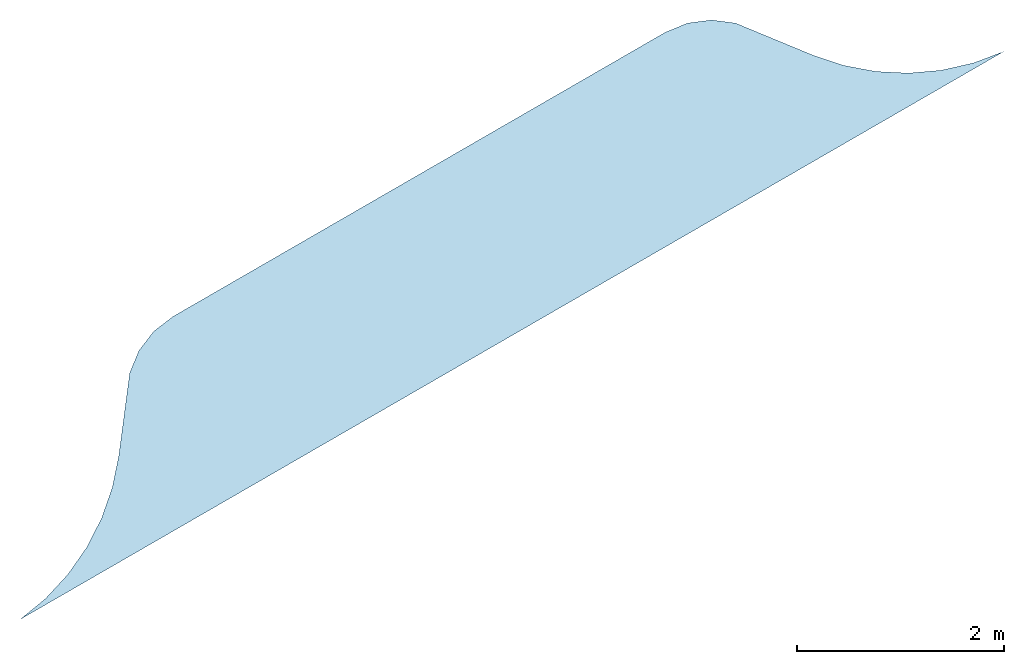
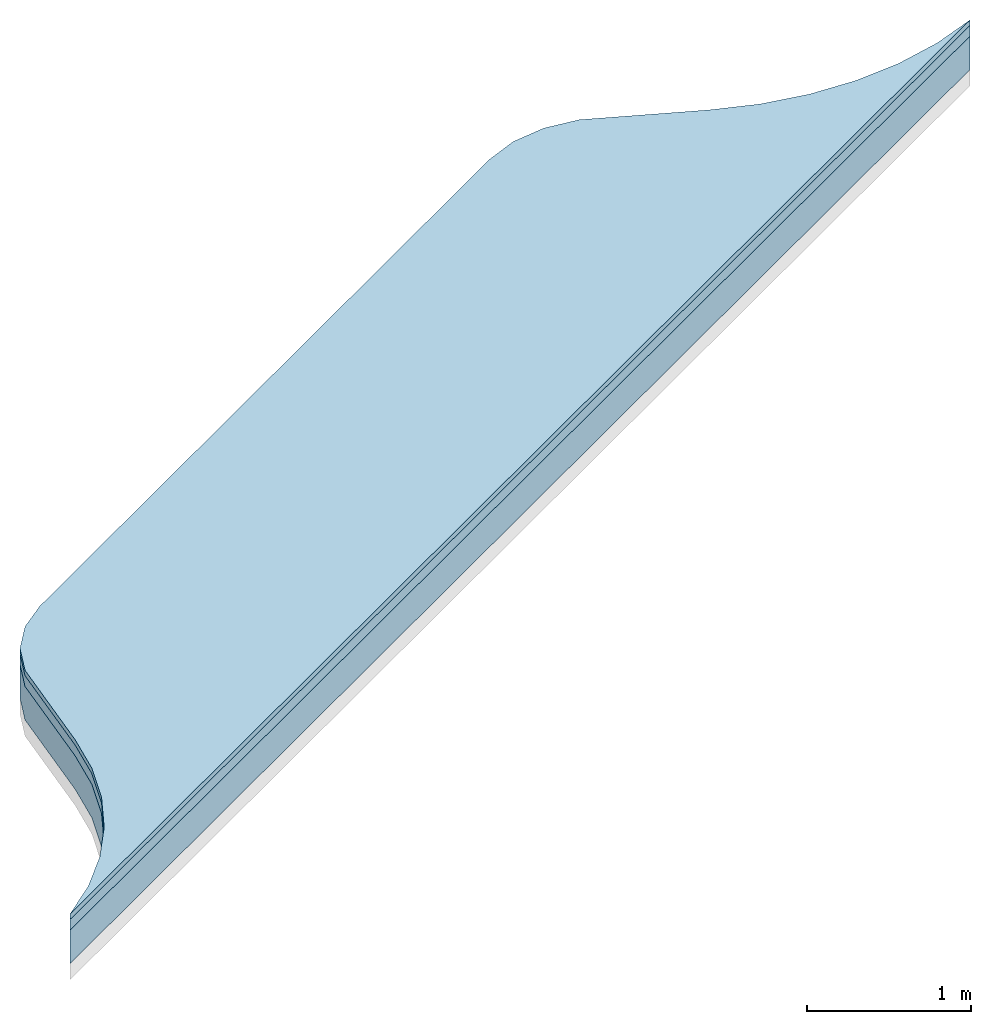
# One storey, part 1 of 2: 3 slabs.
"""IFC4 building model written with IfcOpenShell, lengths in millimetres."""

from ifc_helpers import new_model, si_unit, frame, origin_with_axes, place, context, subcontext, project, spatial, triangles, material, type_object, element, save


model = new_model("IFC4")

# Units and contexts
model_context = context("Model", 3, world=origin_with_axes())
body_context = subcontext(model_context, "Body", "Model", "MODEL_VIEW")
ifc_project = project(units=[si_unit("LENGTHUNIT", "METRE", prefix="MILLI"), si_unit("AREAUNIT", "SQUARE_METRE"), si_unit("VOLUMEUNIT", "CUBIC_METRE")], contexts=[model_context])

# Sites, buildings, storey
site_1_placement = place(None, origin_with_axes())
site_1 = spatial("IfcSite", under=ifc_project, at=site_1_placement, CompositionType="COMPLEX")
site_2_placement = place(site_1_placement, frame((1.7108101132749372e-11, 20000.000000000055, 0.0), z_axis=(0.0, 0.0, 1.0), x_axis=(-0.5000000000000002, 0.8660254037844387, 0.0)))
site_2 = spatial("IfcSite", under=site_1, at=site_2_placement, CompositionType="PARTIAL")
building_1_placement = place(site_2_placement, origin_with_axes())
building_1 = spatial("IfcBuilding", under=site_2, at=building_1_placement, Name="road parking - road", CompositionType="COMPLEX")
building_2_placement = place(building_1_placement, origin_with_axes())
building_2 = spatial("IfcBuilding", under=building_1, at=building_2_placement, Name="road parking - road segment", CompositionType="PARTIAL")
storey_placement = place(building_2_placement, origin_with_axes())
storey = spatial("IfcBuildingStorey", under=building_2, at=storey_placement, Name="road - parking", CompositionType="ELEMENT", Elevation=0.0)

# Slabs
ifc_material_1 = material(Name="bitumen_generic")
slab_type_1 = type_object("IfcSlabType", Name="asphalt course - road - parking", PredefinedType="USERDEFINED")
slab_1_placement = place(storey_placement, frame((7.796643330948427e-11, 8.060862910497234e-09, -9.023892744153272e-14), z_axis=(0.0, 0.0, 1.0), x_axis=(1.0, -1.1102230246251563e-16, 0.0)))
element("IfcSlab", 1, at=slab_1_placement, inside=storey, type_object=slab_type_1, material=ifc_material_1, Name="asphalt course - road - parking", ObjectType="core", context=body_context, shape_type="Tessellation", body=[
    triangles([(1800.0000000000064, -5500.000000008069, -39.99999999999848), (1851.8261465675155, 5185.984337374847, -39.999999999998295), (1799.9999999999834, 5499.999999991909, -39.99999999999848), (1851.8261465675148, -5185.984337390999, -39.999999999998295), (1946.0097838825307, -4881.975738336651, -39.999999999998025), (1946.009783882538, 4881.975738320503, -39.999999999998025), (2080.7895459400906, -4593.65958967934, -39.99999999999785), (2080.789545940087, 4593.659589663187, -39.99999999999785), (2253.6448623118463, 4326.427807423671, -39.99999999999766), (2253.6448623118577, -4326.427807439842, -39.99999999999766), (2461.3430963454293, 4085.278000423549, -39.999999999997485), (2461.343096345443, -4085.278000439709, -39.999999999997485), (2699.999999999992, 3874.720007996512, -39.99999999999739), (2699.999999999992, -3874.7200080126704, -39.99999999999739), (3336.3961030678715, -3386.396103083948, -39.99999999999739), (3336.396103067877, 3386.3961030677874, -39.99999999999739), (3479.422863405981, -3200.000000016058, -39.99999999999739), (3479.422863405978, 3199.999999999902, -39.99999999999739), (3569.3332436601595, 2982.937140592181, -39.99999999999739), (3569.333243660166, -2982.9371406083383, -39.99999999999739), (3600.0, 2749.999999999885, -39.99999999999739), (3600.000000000016, -2750.000000000095, -39.99999999999739), (1851.8261465675155, 5185.984337374847, -119.99999999999876), (1800.0000000000064, -5500.000000008069, -119.99999999999876), (1799.9999999999834, 5499.999999991909, -119.99999999999876), (1851.8261465675141, -5185.984337390999, -119.99999999999876), (1946.0097838825286, -4881.97573833665, -119.99999999999841), (1946.009783882538, 4881.975738320503, -119.99999999999841), (2080.7895459400884, -4593.65958967934, -119.99999999999804), (2080.789545940087, 4593.659589663187, -119.99999999999804), (2253.6448623118463, 4326.427807423671, -119.99999999999804), (2253.6448623118577, -4326.427807439842, -119.99999999999804), (2461.3430963454293, 4085.278000423549, -119.99999999999768), (2461.343096345443, -4085.278000439709, -119.99999999999768), (2699.999999999992, 3874.720007996512, -119.99999999999768), (2699.999999999992, -3874.7200080126704, -119.99999999999768), (3336.396103067877, 3386.3961030677874, -119.99999999999768), (3336.3961030678715, -3386.396103083948, -119.99999999999768), (3479.4228634059796, -3200.000000016059, -119.99999999999768), (3479.422863405978, 3199.999999999902, -119.99999999999768), (3569.3332436601595, 2982.937140592181, -119.99999999999768), (3569.333243660169, -2982.9371406083364, -119.99999999999768), (3600.0, 2749.999999999885, -119.99999999999768), (3600.000000000016, -2750.000000000095, -119.99999999999768), (1799.9999999999834, 5499.999999991909, -39.99999999999848), (1800.0000000000064, -5500.000000008069, -119.99999999999876), (1800.0000000000064, -5500.000000008069, -39.99999999999848), (1799.9999999999834, 5499.999999991909, -119.99999999999876), (1851.8261465675148, -5185.984337390999, -39.999999999998295), (1800.0000000000064, -5500.000000008069, -119.99999999999876), (1851.8261465675141, -5185.984337390999, -119.99999999999876), (1800.0000000000064, -5500.000000008069, -39.99999999999848), (1946.0097838825286, -4881.97573833665, -119.99999999999841), (1851.8261465675148, -5185.984337390999, -39.999999999998295), (1851.8261465675141, -5185.984337390999, -119.99999999999876), (1946.0097838825307, -4881.975738336651, -39.999999999998025), (2080.7895459400884, -4593.65958967934, -119.99999999999804), (1946.0097838825307, -4881.975738336651, -39.999999999998025), (1946.0097838825286, -4881.97573833665, -119.99999999999841), (2080.7895459400906, -4593.65958967934, -39.99999999999785), (2253.6448623118577, -4326.427807439842, -39.99999999999766), (2080.7895459400884, -4593.65958967934, -119.99999999999804), (2253.6448623118577, -4326.427807439842, -119.99999999999804), (2080.7895459400906, -4593.65958967934, -39.99999999999785), (2461.343096345443, -4085.278000439709, -119.99999999999768), (2253.6448623118577, -4326.427807439842, -39.99999999999766), (2253.6448623118577, -4326.427807439842, -119.99999999999804), (2461.343096345443, -4085.278000439709, -39.999999999997485), (2699.999999999992, -3874.7200080126704, -39.99999999999739), (2461.343096345443, -4085.278000439709, -119.99999999999768), (2699.999999999992, -3874.7200080126704, -119.99999999999768), (2461.343096345443, -4085.278000439709, -39.999999999997485), (3336.3961030678715, -3386.396103083948, -39.99999999999739), (2699.999999999992, -3874.7200080126704, -119.99999999999768), (3336.3961030678715, -3386.396103083948, -119.99999999999768), (2699.999999999992, -3874.7200080126704, -39.99999999999739), (3479.422863405981, -3200.000000016058, -39.99999999999739), (3336.3961030678715, -3386.396103083948, -119.99999999999768), (3479.4228634059796, -3200.000000016059, -119.99999999999768), (3336.3961030678715, -3386.396103083948, -39.99999999999739), (3569.333243660166, -2982.9371406083383, -39.99999999999739), (3479.4228634059796, -3200.000000016059, -119.99999999999768), (3569.333243660169, -2982.9371406083364, -119.99999999999768), (3479.422863405981, -3200.000000016058, -39.99999999999739), (3600.000000000016, -2750.000000000095, -39.99999999999739), (3569.333243660169, -2982.9371406083364, -119.99999999999768), (3600.000000000016, -2750.000000000095, -119.99999999999768), (3569.333243660166, -2982.9371406083383, -39.99999999999739), (3479.422863405978, 3199.999999999902, -39.99999999999739), (3569.3332436601595, 2982.937140592181, -119.99999999999768), (3479.422863405978, 3199.999999999902, -119.99999999999768), (3569.3332436601595, 2982.937140592181, -39.99999999999739), (3336.396103067877, 3386.3961030677874, -39.99999999999739), (3479.422863405978, 3199.999999999902, -119.99999999999768), (3336.396103067877, 3386.3961030677874, -119.99999999999768), (3479.422863405978, 3199.999999999902, -39.99999999999739), (2699.999999999992, 3874.720007996512, -39.99999999999739), (3336.396103067877, 3386.3961030677874, -119.99999999999768), (2699.999999999992, 3874.720007996512, -119.99999999999768), (3336.396103067877, 3386.3961030677874, -39.99999999999739), (2461.3430963454293, 4085.278000423549, -39.999999999997485), (2699.999999999992, 3874.720007996512, -119.99999999999768), (2461.3430963454293, 4085.278000423549, -119.99999999999768), (2699.999999999992, 3874.720007996512, -39.99999999999739), (2253.6448623118463, 4326.427807423671, -39.99999999999766), (2461.3430963454293, 4085.278000423549, -119.99999999999768), (2253.6448623118463, 4326.427807423671, -119.99999999999804), (2461.3430963454293, 4085.278000423549, -39.999999999997485), (2080.789545940087, 4593.659589663187, -39.99999999999785), (2253.6448623118463, 4326.427807423671, -119.99999999999804), (2080.789545940087, 4593.659589663187, -119.99999999999804), (2253.6448623118463, 4326.427807423671, -39.99999999999766), (1946.009783882538, 4881.975738320503, -39.999999999998025), (2080.789545940087, 4593.659589663187, -119.99999999999804), (1946.009783882538, 4881.975738320503, -119.99999999999841), (2080.789545940087, 4593.659589663187, -39.99999999999785), (1851.8261465675155, 5185.984337374847, -39.999999999998295), (1946.009783882538, 4881.975738320503, -119.99999999999841), (1851.8261465675155, 5185.984337374847, -119.99999999999876), (1946.009783882538, 4881.975738320503, -39.999999999998025), (1799.9999999999834, 5499.999999991909, -39.99999999999848), (1851.8261465675155, 5185.984337374847, -119.99999999999876), (1799.9999999999834, 5499.999999991909, -119.99999999999876), (1851.8261465675155, 5185.984337374847, -39.999999999998295), (3600.0, 2749.999999999885, -119.99999999999768), (3600.000000000016, -2750.000000000095, -39.99999999999739), (3600.000000000016, -2750.000000000095, -119.99999999999768), (3600.0, 2749.999999999885, -39.99999999999739), (3569.3332436601595, 2982.937140592181, -39.99999999999739), (3600.0, 2749.999999999885, -119.99999999999768), (3569.3332436601595, 2982.937140592181, -119.99999999999768), (3600.0, 2749.999999999885, -39.99999999999739)], [[1, 2, 3], [2, 1, 4], [2, 4, 5], [2, 5, 6], [6, 5, 7], [6, 7, 8], [8, 7, 9], [9, 7, 10], [9, 10, 11], [11, 10, 12], [11, 12, 13], [13, 12, 14], [13, 14, 15], [13, 15, 16], [16, 15, 17], [16, 17, 18], [18, 17, 19], [19, 17, 20], [19, 20, 21], [21, 20, 22], [23, 24, 25], [24, 23, 26], [26, 23, 27], [27, 23, 28], [27, 28, 29], [29, 28, 30], [29, 30, 31], [29, 31, 32], [32, 31, 33], [32, 33, 34], [34, 33, 35], [34, 35, 36], [36, 35, 37], [36, 37, 38], [38, 37, 39], [39, 37, 40], [39, 40, 41], [39, 41, 42], [42, 41, 43], [42, 43, 44], [45, 46, 47], [46, 45, 48], [49, 50, 51], [50, 49, 52], [53, 54, 55], [54, 53, 56], [57, 58, 59], [58, 57, 60], [61, 62, 63], [62, 61, 64], [65, 66, 67], [66, 65, 68], [69, 70, 71], [70, 69, 72], [73, 74, 75], [74, 73, 76], [77, 78, 79], [78, 77, 80], [81, 82, 83], [82, 81, 84], [85, 86, 87], [86, 85, 88], [89, 90, 91], [90, 89, 92], [93, 94, 95], [94, 93, 96], [97, 98, 99], [98, 97, 100], [101, 102, 103], [102, 101, 104], [105, 106, 107], [106, 105, 108], [109, 110, 111], [110, 109, 112], [113, 114, 115], [114, 113, 116], [117, 118, 119], [118, 117, 120], [121, 122, 123], [122, 121, 124], [125, 126, 127], [126, 125, 128], [129, 130, 131], [130, 129, 132]]),
])
ifc_material_2 = material(Name="bitumen_asphalt_generic")
slab_type_2 = type_object("IfcSlabType", Name="road - parking - asphalt surface course", PredefinedType="USERDEFINED")
slab_2_placement = place(storey_placement, frame((7.796643330948427e-11, 8.060862910497234e-09, -9.023892744153272e-14), z_axis=(0.0, 0.0, 1.0), x_axis=(1.0, -1.1102230246251563e-16, 0.0)))
element("IfcSlab", 2, at=slab_2_placement, inside=storey, type_object=slab_type_2, material=ifc_material_2, Name="road - parking - asphalt surface course", ObjectType="pavement", context=body_context, shape_type="Tessellation", body=[
    triangles([(1800.0000000000036, -5500.000000008059, 1.0828671292983925e-12), (1851.8261465675055, 5185.984337374858, 1.2633449841814578e-12), (1799.9999999999804, 5499.99999999192, 1.0828671292983925e-12), (1851.8261465675112, -5185.984337390988, 1.2633449841814578e-12), (1946.0097838825316, 4881.975738320513, 1.534061766506056e-12), (1946.0097838825257, -4881.975738336639, 1.534061766506056e-12), (2080.7895459400856, -4593.6595896793315, 1.7145396213891214e-12), (2080.789545940083, 4593.659589663194, 1.7145396213891214e-12), (2253.644862311841, 4326.427807423691, 1.8950174762721867e-12), (2253.644862311853, -4326.427807439833, 1.8950174762721867e-12), (2461.3430963454225, 4085.278000423555, 2.0754953311552524e-12), (2461.3430963454384, -4085.2780004397014, 2.0754953311552524e-12), (2699.9999999999873, 3874.7200079965246, 2.165734258596785e-12), (2699.999999999988, -3874.720008012663, 2.165734258596785e-12), (3336.3961030678697, 3386.3961030677947, 2.165734258596785e-12), (3336.3961030678665, -3386.3961030839364, 2.165734258596785e-12), (3479.422863405975, -3200.00000001605, 2.165734258596785e-12), (3479.42286340597, 3199.999999999909, 2.165734258596785e-12), (3569.3332436601554, 2982.9371405921847, 2.165734258596785e-12), (3569.333243660163, -2982.9371406083255, 2.165734258596785e-12), (3599.9999999999955, 2749.999999999894, 2.165734258596785e-12), (3600.0000000000114, -2750.000000000086, 2.165734258596785e-12), (1851.8261465675055, 5185.984337374858, -39.999999999998025), (1800.0000000000027, -5500.00000000806, -39.999999999998025), (1799.9999999999775, 5499.99999999192, -39.999999999998025), (1851.8261465675105, -5185.984337390989, -39.999999999998025), (1946.0097838825316, 4881.975738320513, -39.99999999999766), (1946.0097838825243, -4881.9757383366405, -39.99999999999766), (2080.7895459400834, -4593.6595896793315, -39.99999999999766), (2080.7895459400806, 4593.659589663193, -39.99999999999766), (2253.6448623118404, 4326.427807423687, -39.99999999999731), (2253.6448623118517, -4326.427807439833, -39.99999999999731), (2461.3430963454207, 4085.2780004235588, -39.999999999996945), (2461.3430963454357, -4085.2780004397005, -39.999999999996945), (2699.9999999999873, 3874.7200079965246, -39.999999999996945), (2699.999999999985, -3874.7200080126645, -39.999999999996945), (3336.396103067866, -3386.3961030839364, -39.999999999996945), (3336.396103067868, 3386.3961030677947, -39.999999999996945), (3479.422863405975, -3200.00000001605, -39.999999999996945), (3479.42286340597, 3199.999999999909, -39.999999999996945), (3569.3332436601554, 2982.9371405921847, -39.999999999996945), (3569.333243660163, -2982.9371406083255, -39.999999999996945), (3599.9999999999955, 2749.999999999894, -39.999999999996945), (3600.0000000000086, -2750.0000000000873, -39.999999999996945), (1800.0000000000036, -5500.000000008059, 1.0828671292983925e-12), (1799.9999999999775, 5499.99999999192, -39.999999999998025), (1800.0000000000027, -5500.00000000806, -39.999999999998025), (1799.9999999999804, 5499.99999999192, 1.0828671292983925e-12), (1851.8261465675112, -5185.984337390988, 1.2633449841814578e-12), (1800.0000000000027, -5500.00000000806, -39.999999999998025), (1851.8261465675105, -5185.984337390989, -39.999999999998025), (1800.0000000000036, -5500.000000008059, 1.0828671292983925e-12), (1946.0097838825243, -4881.9757383366405, -39.99999999999766), (1851.8261465675112, -5185.984337390988, 1.2633449841814578e-12), (1851.8261465675105, -5185.984337390989, -39.999999999998025), (1946.0097838825257, -4881.975738336639, 1.534061766506056e-12), (2080.7895459400856, -4593.6595896793315, 1.7145396213891214e-12), (1946.0097838825243, -4881.9757383366405, -39.99999999999766), (2080.7895459400834, -4593.6595896793315, -39.99999999999766), (1946.0097838825257, -4881.975738336639, 1.534061766506056e-12), (2253.6448623118517, -4326.427807439833, -39.99999999999731), (2080.7895459400856, -4593.6595896793315, 1.7145396213891214e-12), (2080.7895459400834, -4593.6595896793315, -39.99999999999766), (2253.644862311853, -4326.427807439833, 1.8950174762721867e-12), (2461.3430963454357, -4085.2780004397005, -39.999999999996945), (2253.644862311853, -4326.427807439833, 1.8950174762721867e-12), (2253.6448623118517, -4326.427807439833, -39.99999999999731), (2461.3430963454384, -4085.2780004397014, 2.0754953311552524e-12), (2699.999999999988, -3874.720008012663, 2.165734258596785e-12), (2461.3430963454357, -4085.2780004397005, -39.999999999996945), (2699.999999999985, -3874.7200080126645, -39.999999999996945), (2461.3430963454384, -4085.2780004397014, 2.0754953311552524e-12), (3336.3961030678665, -3386.3961030839364, 2.165734258596785e-12), (2699.999999999985, -3874.7200080126645, -39.999999999996945), (3336.396103067866, -3386.3961030839364, -39.999999999996945), (2699.999999999988, -3874.720008012663, 2.165734258596785e-12), (3479.422863405975, -3200.00000001605, 2.165734258596785e-12), (3336.396103067866, -3386.3961030839364, -39.999999999996945), (3479.422863405975, -3200.00000001605, -39.999999999996945), (3336.3961030678665, -3386.3961030839364, 2.165734258596785e-12), (3569.333243660163, -2982.9371406083255, 2.165734258596785e-12), (3479.422863405975, -3200.00000001605, -39.999999999996945), (3569.333243660163, -2982.9371406083255, -39.999999999996945), (3479.422863405975, -3200.00000001605, 2.165734258596785e-12), (3600.0000000000114, -2750.000000000086, 2.165734258596785e-12), (3569.333243660163, -2982.9371406083255, -39.999999999996945), (3600.0000000000086, -2750.0000000000873, -39.999999999996945), (3569.333243660163, -2982.9371406083255, 2.165734258596785e-12), (3599.9999999999955, 2749.999999999894, -39.999999999996945), (3600.0000000000114, -2750.000000000086, 2.165734258596785e-12), (3600.0000000000086, -2750.0000000000873, -39.999999999996945), (3599.9999999999955, 2749.999999999894, 2.165734258596785e-12), (3569.3332436601554, 2982.9371405921847, 2.165734258596785e-12), (3599.9999999999955, 2749.999999999894, -39.999999999996945), (3569.3332436601554, 2982.9371405921847, -39.999999999996945), (3599.9999999999955, 2749.999999999894, 2.165734258596785e-12), (3479.42286340597, 3199.999999999909, 2.165734258596785e-12), (3569.3332436601554, 2982.9371405921847, -39.999999999996945), (3479.42286340597, 3199.999999999909, -39.999999999996945), (3569.3332436601554, 2982.9371405921847, 2.165734258596785e-12), (3336.3961030678697, 3386.3961030677947, 2.165734258596785e-12), (3479.42286340597, 3199.999999999909, -39.999999999996945), (3336.396103067868, 3386.3961030677947, -39.999999999996945), (3479.42286340597, 3199.999999999909, 2.165734258596785e-12), (2699.9999999999873, 3874.7200079965246, 2.165734258596785e-12), (3336.396103067868, 3386.3961030677947, -39.999999999996945), (2699.9999999999873, 3874.7200079965246, -39.999999999996945), (3336.3961030678697, 3386.3961030677947, 2.165734258596785e-12), (2461.3430963454225, 4085.278000423555, 2.0754953311552524e-12), (2699.9999999999873, 3874.7200079965246, -39.999999999996945), (2461.3430963454207, 4085.2780004235588, -39.999999999996945), (2699.9999999999873, 3874.7200079965246, 2.165734258596785e-12), (2253.644862311841, 4326.427807423691, 1.8950174762721867e-12), (2461.3430963454207, 4085.2780004235588, -39.999999999996945), (2253.6448623118404, 4326.427807423687, -39.99999999999731), (2461.3430963454225, 4085.278000423555, 2.0754953311552524e-12), (2080.789545940083, 4593.659589663194, 1.7145396213891214e-12), (2253.6448623118404, 4326.427807423687, -39.99999999999731), (2080.7895459400806, 4593.659589663193, -39.99999999999766), (2253.644862311841, 4326.427807423691, 1.8950174762721867e-12), (1946.0097838825316, 4881.975738320513, 1.534061766506056e-12), (2080.7895459400806, 4593.659589663193, -39.99999999999766), (1946.0097838825316, 4881.975738320513, -39.99999999999766), (2080.789545940083, 4593.659589663194, 1.7145396213891214e-12), (1851.8261465675055, 5185.984337374858, 1.2633449841814578e-12), (1946.0097838825316, 4881.975738320513, -39.99999999999766), (1851.8261465675055, 5185.984337374858, -39.999999999998025), (1946.0097838825316, 4881.975738320513, 1.534061766506056e-12), (1799.9999999999804, 5499.99999999192, 1.0828671292983925e-12), (1851.8261465675055, 5185.984337374858, -39.999999999998025), (1799.9999999999775, 5499.99999999192, -39.999999999998025), (1851.8261465675055, 5185.984337374858, 1.2633449841814578e-12)], [[1, 2, 3], [2, 1, 4], [2, 4, 5], [5, 4, 6], [5, 6, 7], [5, 7, 8], [8, 7, 9], [9, 7, 10], [9, 10, 11], [11, 10, 12], [11, 12, 13], [13, 12, 14], [13, 14, 15], [15, 14, 16], [15, 16, 17], [15, 17, 18], [18, 17, 19], [19, 17, 20], [19, 20, 21], [21, 20, 22], [23, 24, 25], [24, 23, 26], [26, 23, 27], [26, 27, 28], [28, 27, 29], [29, 27, 30], [29, 30, 31], [29, 31, 32], [32, 31, 33], [32, 33, 34], [34, 33, 35], [34, 35, 36], [36, 35, 37], [37, 35, 38], [37, 38, 39], [39, 38, 40], [39, 40, 41], [39, 41, 42], [42, 41, 43], [42, 43, 44], [45, 46, 47], [46, 45, 48], [49, 50, 51], [50, 49, 52], [53, 54, 55], [54, 53, 56], [57, 58, 59], [58, 57, 60], [61, 62, 63], [62, 61, 64], [65, 66, 67], [66, 65, 68], [69, 70, 71], [70, 69, 72], [73, 74, 75], [74, 73, 76], [77, 78, 79], [78, 77, 80], [81, 82, 83], [82, 81, 84], [85, 86, 87], [86, 85, 88], [89, 90, 91], [90, 89, 92], [93, 94, 95], [94, 93, 96], [97, 98, 99], [98, 97, 100], [101, 102, 103], [102, 101, 104], [105, 106, 107], [106, 105, 108], [109, 110, 111], [110, 109, 112], [113, 114, 115], [114, 113, 116], [117, 118, 119], [118, 117, 120], [121, 122, 123], [122, 121, 124], [125, 126, 127], [126, 125, 128], [129, 130, 131], [130, 129, 132]]),
])
ifc_material_3 = material(Name="material_gravel_generic")
slab_type_3 = type_object("IfcSlabType", Name="road - parking", PredefinedType="USERDEFINED")
slab_3_placement = place(storey_placement, frame((6.930349627509712e-11, 8.060862910497234e-09, -9.023892744153272e-14), z_axis=(0.0, 0.0, 1.0), x_axis=(1.0, -3.885780586188048e-16, 0.0)))
element("IfcSlab", 3, at=slab_3_placement, inside=storey, type_object=slab_type_3, material=ifc_material_3, Name="road - parking", context=body_context, shape_type="Tessellation", body=[
    triangles([(1800.0000000000068, -5500.000000008068, -119.9999999999968), (1851.8261465675066, 5185.984337374844, -119.99999999999645), (1799.9999999999793, 5499.999999991909, -119.9999999999968), (1851.8261465675153, -5185.984337390998, -119.99999999999645), (1946.0097838825377, 4881.9757383205, -119.99999999999645), (1946.0097838825304, -4881.975738336649, -119.99999999999645), (2080.7895459400897, -4593.65958967934, -119.99999999999608), (2080.789545940085, 4593.6595896631825, -119.99999999999608), (2253.6448623118436, 4326.427807423671, -119.99999999999608), (2253.644862311858, -4326.42780743984, -119.99999999999608), (2461.343096345426, 4085.278000423544, -119.99999999999572), (2461.3430963454416, -4085.2780004397105, -119.99999999999572), (2699.9999999999923, 3874.7200079965105, -119.99999999999572), (2699.9999999999923, -3874.720008012671, -119.99999999999572), (3336.3961030678697, -3386.396103083948, -119.99999999999572), (3336.396103067874, 3386.3961030677824, -119.99999999999572), (3479.422863405981, -3200.0000000160585, -119.99999999999572), (3479.422863405976, 3199.999999999899, -119.99999999999572), (3569.3332436601568, 2982.9371405921734, -119.99999999999572), (3569.3332436601668, -2982.937140608335, -119.99999999999572), (3600.0000000000014, 2749.9999999998845, -119.99999999999572), (3600.000000000016, -2750.000000000096, -119.99999999999572), (1851.826146567505, 5185.984337374844, -369.9999999999916), (1800.0000000000061, -5500.000000008068, -369.9999999999916), (1799.9999999999793, 5499.999999991907, -369.9999999999916), (1851.8261465675146, -5185.984337390998, -369.9999999999916), (1946.009783882536, 4881.975738320499, -369.9999999999916), (1946.0097838825288, -4881.97573833665, -369.9999999999916), (2080.789545940088, -4593.65958967934, -369.99999999999085), (2080.789545940084, 4593.6595896631825, -369.99999999999085), (2253.644862311842, 4326.427807423671, -369.99999999999085), (2253.6448623118567, -4326.427807439841, -369.99999999999085), (2461.343096345425, 4085.278000423543, -369.99999999999085), (2461.3430963454393, -4085.2780004397114, -369.99999999999085), (2699.999999999991, 3874.7200079965105, -369.99999999999085), (2699.999999999991, -3874.7200080126727, -369.99999999999085), (3336.3961030678724, 3386.396103067781, -369.99999999999085), (3336.396103067868, -3386.396103083948, -369.99999999999085), (3479.4228634059787, -3200.0000000160594, -369.99999999999085), (3479.4228634059746, 3199.999999999897, -369.99999999999085), (3569.3332436601554, 2982.9371405921734, -369.99999999999085), (3569.3332436601654, -2982.9371406083355, -369.99999999999085), (3600.0000000000014, 2749.9999999998845, -369.99999999999085), (3600.0000000000146, -2750.0000000000964, -369.99999999999085), (1799.9999999999793, 5499.999999991909, -119.9999999999968), (1800.0000000000061, -5500.000000008068, -369.9999999999916), (1800.0000000000068, -5500.000000008068, -119.9999999999968), (1799.9999999999793, 5499.999999991907, -369.9999999999916), (1851.8261465675153, -5185.984337390998, -119.99999999999645), (1800.0000000000061, -5500.000000008068, -369.9999999999916), (1851.8261465675146, -5185.984337390998, -369.9999999999916), (1800.0000000000068, -5500.000000008068, -119.9999999999968), (1946.0097838825304, -4881.975738336649, -119.99999999999645), (1851.8261465675146, -5185.984337390998, -369.9999999999916), (1946.0097838825288, -4881.97573833665, -369.9999999999916), (1851.8261465675153, -5185.984337390998, -119.99999999999645), (2080.789545940088, -4593.65958967934, -369.99999999999085), (1946.0097838825304, -4881.975738336649, -119.99999999999645), (1946.0097838825288, -4881.97573833665, -369.9999999999916), (2080.7895459400897, -4593.65958967934, -119.99999999999608), (2253.644862311858, -4326.42780743984, -119.99999999999608), (2080.789545940088, -4593.65958967934, -369.99999999999085), (2253.6448623118567, -4326.427807439841, -369.99999999999085), (2080.7895459400897, -4593.65958967934, -119.99999999999608), (2461.3430963454416, -4085.2780004397105, -119.99999999999572), (2253.6448623118567, -4326.427807439841, -369.99999999999085), (2461.3430963454393, -4085.2780004397114, -369.99999999999085), (2253.644862311858, -4326.42780743984, -119.99999999999608), (2699.9999999999923, -3874.720008012671, -119.99999999999572), (2461.3430963454393, -4085.2780004397114, -369.99999999999085), (2699.999999999991, -3874.7200080126727, -369.99999999999085), (2461.3430963454416, -4085.2780004397105, -119.99999999999572), (3336.3961030678697, -3386.396103083948, -119.99999999999572), (2699.999999999991, -3874.7200080126727, -369.99999999999085), (3336.396103067868, -3386.396103083948, -369.99999999999085), (2699.9999999999923, -3874.720008012671, -119.99999999999572), (3479.422863405981, -3200.0000000160585, -119.99999999999572), (3336.396103067868, -3386.396103083948, -369.99999999999085), (3479.4228634059787, -3200.0000000160594, -369.99999999999085), (3336.3961030678697, -3386.396103083948, -119.99999999999572), (3569.3332436601668, -2982.937140608335, -119.99999999999572), (3479.4228634059787, -3200.0000000160594, -369.99999999999085), (3569.3332436601654, -2982.9371406083355, -369.99999999999085), (3479.422863405981, -3200.0000000160585, -119.99999999999572), (3600.000000000016, -2750.000000000096, -119.99999999999572), (3569.3332436601654, -2982.9371406083355, -369.99999999999085), (3600.0000000000146, -2750.0000000000964, -369.99999999999085), (3569.3332436601668, -2982.937140608335, -119.99999999999572), (3600.0000000000014, 2749.9999999998845, -369.99999999999085), (3600.000000000016, -2750.000000000096, -119.99999999999572), (3600.0000000000146, -2750.0000000000964, -369.99999999999085), (3600.0000000000014, 2749.9999999998845, -119.99999999999572), (3569.3332436601568, 2982.9371405921734, -119.99999999999572), (3600.0000000000014, 2749.9999999998845, -369.99999999999085), (3569.3332436601554, 2982.9371405921734, -369.99999999999085), (3600.0000000000014, 2749.9999999998845, -119.99999999999572), (3479.422863405976, 3199.999999999899, -119.99999999999572), (3569.3332436601554, 2982.9371405921734, -369.99999999999085), (3479.4228634059746, 3199.999999999897, -369.99999999999085), (3569.3332436601568, 2982.9371405921734, -119.99999999999572), (3336.396103067874, 3386.3961030677824, -119.99999999999572), (3479.4228634059746, 3199.999999999897, -369.99999999999085), (3336.3961030678724, 3386.396103067781, -369.99999999999085), (3479.422863405976, 3199.999999999899, -119.99999999999572), (2699.9999999999923, 3874.7200079965105, -119.99999999999572), (3336.3961030678724, 3386.396103067781, -369.99999999999085), (2699.999999999991, 3874.7200079965105, -369.99999999999085), (3336.396103067874, 3386.3961030677824, -119.99999999999572), (2461.343096345426, 4085.278000423544, -119.99999999999572), (2699.999999999991, 3874.7200079965105, -369.99999999999085), (2461.343096345425, 4085.278000423543, -369.99999999999085), (2699.9999999999923, 3874.7200079965105, -119.99999999999572), (2253.6448623118436, 4326.427807423671, -119.99999999999608), (2461.343096345425, 4085.278000423543, -369.99999999999085), (2253.644862311842, 4326.427807423671, -369.99999999999085), (2461.343096345426, 4085.278000423544, -119.99999999999572), (2080.789545940085, 4593.6595896631825, -119.99999999999608), (2253.644862311842, 4326.427807423671, -369.99999999999085), (2080.789545940084, 4593.6595896631825, -369.99999999999085), (2253.6448623118436, 4326.427807423671, -119.99999999999608), (1946.0097838825377, 4881.9757383205, -119.99999999999645), (2080.789545940084, 4593.6595896631825, -369.99999999999085), (1946.009783882536, 4881.975738320499, -369.9999999999916), (2080.789545940085, 4593.6595896631825, -119.99999999999608), (1851.8261465675066, 5185.984337374844, -119.99999999999645), (1946.009783882536, 4881.975738320499, -369.9999999999916), (1851.826146567505, 5185.984337374844, -369.9999999999916), (1946.0097838825377, 4881.9757383205, -119.99999999999645), (1799.9999999999793, 5499.999999991909, -119.9999999999968), (1851.826146567505, 5185.984337374844, -369.9999999999916), (1799.9999999999793, 5499.999999991907, -369.9999999999916), (1851.8261465675066, 5185.984337374844, -119.99999999999645)], [[1, 2, 3], [2, 1, 4], [2, 4, 5], [5, 4, 6], [5, 6, 7], [5, 7, 8], [8, 7, 9], [9, 7, 10], [9, 10, 11], [11, 10, 12], [11, 12, 13], [13, 12, 14], [13, 14, 15], [13, 15, 16], [16, 15, 17], [16, 17, 18], [18, 17, 19], [19, 17, 20], [19, 20, 21], [21, 20, 22], [23, 24, 25], [24, 23, 26], [26, 23, 27], [26, 27, 28], [28, 27, 29], [29, 27, 30], [29, 30, 31], [29, 31, 32], [32, 31, 33], [32, 33, 34], [34, 33, 35], [34, 35, 36], [36, 35, 37], [36, 37, 38], [38, 37, 39], [39, 37, 40], [39, 40, 41], [39, 41, 42], [42, 41, 43], [42, 43, 44], [45, 46, 47], [46, 45, 48], [49, 50, 51], [50, 49, 52], [53, 54, 55], [54, 53, 56], [57, 58, 59], [58, 57, 60], [61, 62, 63], [62, 61, 64], [65, 66, 67], [66, 65, 68], [69, 70, 71], [70, 69, 72], [73, 74, 75], [74, 73, 76], [77, 78, 79], [78, 77, 80], [81, 82, 83], [82, 81, 84], [85, 86, 87], [86, 85, 88], [89, 90, 91], [90, 89, 92], [93, 94, 95], [94, 93, 96], [97, 98, 99], [98, 97, 100], [101, 102, 103], [102, 101, 104], [105, 106, 107], [106, 105, 108], [109, 110, 111], [110, 109, 112], [113, 114, 115], [114, 113, 116], [117, 118, 119], [118, 117, 120], [121, 122, 123], [122, 121, 124], [125, 126, 127], [126, 125, 128], [129, 130, 131], [130, 129, 132]]),
])

save(model, "model.ifc")
